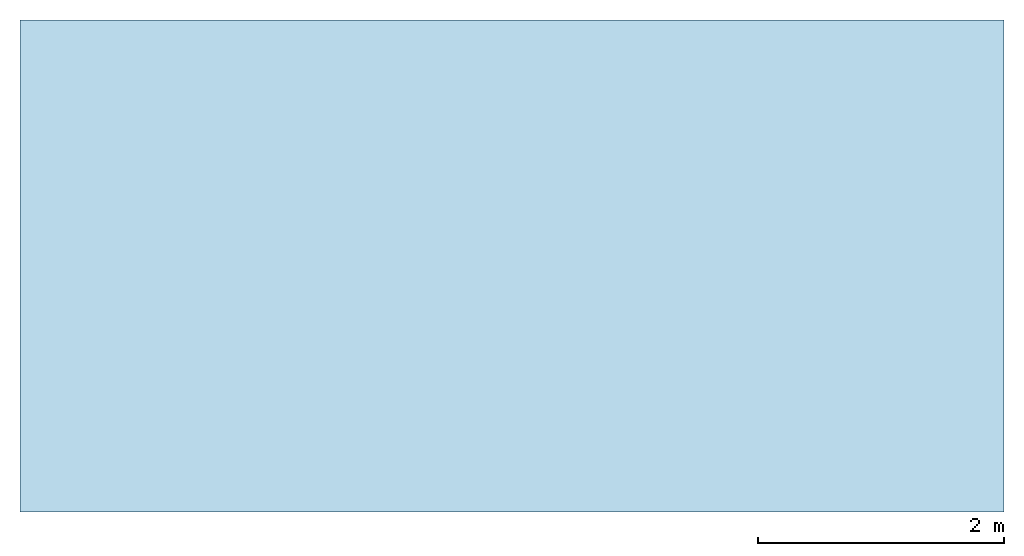
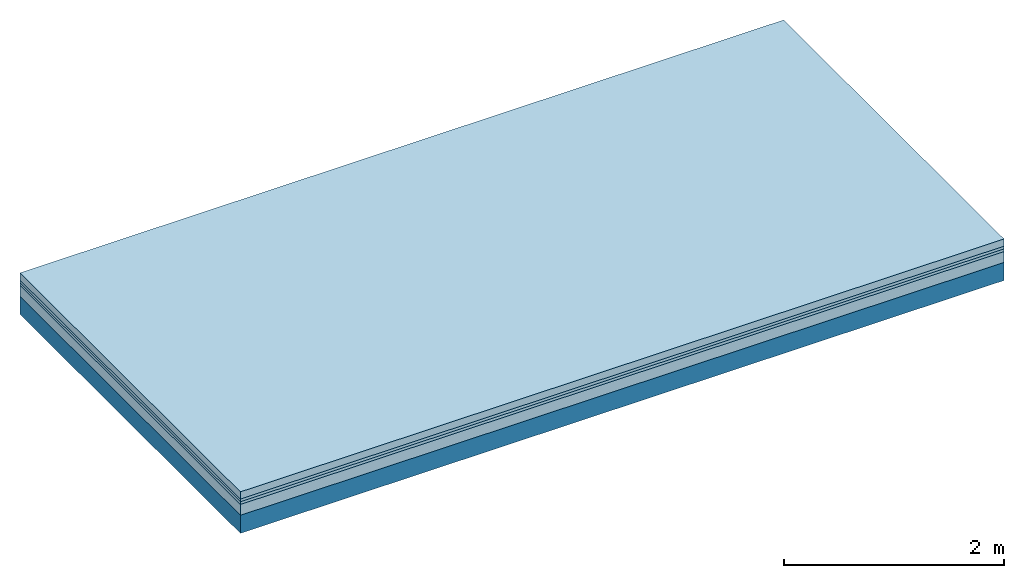
# One storey: 4 plates, 1 member, 1 element without a shape of its own.
"""IFC4 building model written with IfcOpenShell, lengths in metres."""

from ifc_helpers import new_model, si_unit, derived_unit, direction, frame, frame_2d, origin, origin_with_axes, place, context, project, spatial, rectangle, extrude, material, layer, layer_set, type_object, element, aggregate, save


model = new_model("IFC4")

# Units and contexts
plan_context = context("Plan", 3, precision=1e-05, world=origin(), true_north=direction((0.0, 1.0)))
model_context = context("Model", 3, precision=1e-05, world=origin(), true_north=direction((0.0, 1.0)))
ifc_project = project(units=[si_unit("LENGTHUNIT", "METRE"), derived_unit("SOUNDPRESSUREUNIT", [(si_unit("PRESSUREUNIT", "PASCAL", prefix="MICRO"), 0)]), si_unit("ENERGYUNIT", "JOULE", prefix="MEGA"), si_unit("MASSUNIT", "GRAM", prefix="KILO"), derived_unit("THERMALTRANSMITTANCEUNIT", [(si_unit("POWERUNIT", "WATT"), 1), (si_unit("AREAUNIT", "SQUARE_METRE"), -1), (si_unit("THERMODYNAMICTEMPERATUREUNIT", "KELVIN"), -1)]), derived_unit("AREADENSITYUNIT", [(si_unit("MASSUNIT", "GRAM", prefix="KILO"), 1), (si_unit("AREAUNIT", "SQUARE_METRE"), -1)]), derived_unit("USERDEFINED", [(si_unit("ENERGYUNIT", "JOULE", prefix="MEGA"), 1), (si_unit("AREAUNIT", "SQUARE_METRE"), -1)])], contexts=[plan_context, model_context])

# Site, building, storey
site = spatial("IfcSite", under=ifc_project)
building_placement = place(None, origin())
building = spatial("IfcBuilding", under=site, at=building_placement)
storey_placement = place(building_placement, origin())
storey = spatial("IfcBuildingStorey", under=building, at=storey_placement)

# Slab, member, plates
ifc_material_1 = material(Name="Cement screed", Category="04.006")
ifc_layer_1 = layer(ifc_material_1, 0.08, Name="On-material")
ifc_material_2 = material()
ifc_layer_2 = layer(ifc_material_2, 0.03, Name="Impact sound insulation")
ifc_material_3 = material()
ifc_layer_3 = layer(ifc_material_3, 0.03, Name="Additional insulation")
ifc_material_4 = material(Category="03.011")
ifc_layer_4 = layer(ifc_material_4, 0.12, Name="on Supporting structure")
ifc_layer_5 = layer(None, 0.2, Name="Supporting structure")
ifc_layer_set = layer_set([ifc_layer_1, ifc_layer_2, ifc_layer_3, ifc_layer_4, ifc_layer_5])
slab_type = type_object("IfcSlabType", Name="A1097", PredefinedType="NOTDEFINED", material=ifc_layer_set)
slab_placement = place(None, frame((0.0, 0.0, 0.0), z_axis=(0.0, 0.0, -1.0), x_axis=(1.0, 0.0, 0.0)))
slab = element("IfcSlab", 1, at=slab_placement, inside=storey, type_object=slab_type, material=ifc_layer_set, Name="Slab #1")
ifc_material_5 = material()
member_placement = place(slab_placement, origin())
member = element("IfcMember", 2, at=member_placement, material=ifc_material_5, Name="Supporting structure", context=plan_context, shape_type="SweptSolid", body=[
    extrude(rectangle(XDim=1.0, YDim=0.2, at=frame_2d((0.5, 0.1), x_axis=(1.0, 0.0))), frame((0.0, 4.0, 0.26), z_axis=(0.0, -1.0, 0.0), x_axis=(1.0, 0.0, 0.0)), (0.0, 0.0, 1.0), 4.0),
    extrude(rectangle(XDim=1.0, YDim=0.2, at=frame_2d((0.5, 0.1), x_axis=(1.0, 0.0))), frame((1.0, 4.0, 0.26), z_axis=(0.0, -1.0, 0.0), x_axis=(1.0, 0.0, 0.0)), (0.0, 0.0, 1.0), 4.0),
    extrude(rectangle(XDim=1.0, YDim=0.2, at=frame_2d((0.5, 0.1), x_axis=(1.0, 0.0))), frame((2.0, 4.0, 0.26), z_axis=(0.0, -1.0, 0.0), x_axis=(1.0, 0.0, 0.0)), (0.0, 0.0, 1.0), 4.0),
    extrude(rectangle(XDim=1.0, YDim=0.2, at=frame_2d((0.5, 0.1), x_axis=(1.0, 0.0))), frame((3.0, 4.0, 0.26), z_axis=(0.0, -1.0, 0.0), x_axis=(1.0, 0.0, 0.0)), (0.0, 0.0, 1.0), 4.0),
    extrude(rectangle(XDim=1.0, YDim=0.2, at=frame_2d((0.5, 0.1), x_axis=(1.0, 0.0))), frame((4.0, 4.0, 0.26), z_axis=(0.0, -1.0, 0.0), x_axis=(1.0, 0.0, 0.0)), (0.0, 0.0, 1.0), 4.0),
    extrude(rectangle(XDim=1.0, YDim=0.2, at=frame_2d((0.5, 0.1), x_axis=(1.0, 0.0))), frame((5.0, 4.0, 0.26), z_axis=(0.0, -1.0, 0.0), x_axis=(1.0, 0.0, 0.0)), (0.0, 0.0, 1.0), 4.0),
    extrude(rectangle(XDim=1.0, YDim=0.2, at=frame_2d((0.5, 0.1), x_axis=(1.0, 0.0))), frame((6.0, 4.0, 0.26), z_axis=(0.0, -1.0, 0.0), x_axis=(1.0, 0.0, 0.0)), (0.0, 0.0, 1.0), 4.0),
    extrude(rectangle(XDim=1.0, YDim=0.2, at=frame_2d((0.5, 0.1), x_axis=(1.0, 0.0))), frame((7.0, 4.0, 0.26), z_axis=(0.0, -1.0, 0.0), x_axis=(1.0, 0.0, 0.0)), (0.0, 0.0, 1.0), 4.0),
])
plate_1_placement = place(slab_placement, origin())
plate_1 = element("IfcPlate", 3, at=plate_1_placement, material=ifc_material_1, Name="On-material", context=plan_context, shape_type="SweptSolid", body=[
    extrude(rectangle(XDim=8.0, YDim=4.0, at=frame_2d((4.0, 2.0), x_axis=(1.0, 0.0))), origin_with_axes(), (0.0, 0.0, 1.0), 0.08),
])
plate_2_placement = place(slab_placement, origin())
plate_2 = element("IfcPlate", 4, at=plate_2_placement, material=ifc_material_2, Name="Impact sound insulation", context=plan_context, shape_type="SweptSolid", body=[
    extrude(rectangle(XDim=8.0, YDim=4.0, at=frame_2d((4.0, 2.0), x_axis=(1.0, 0.0))), frame((0.0, 0.0, 0.08), z_axis=(0.0, 0.0, 1.0), x_axis=(1.0, 0.0, 0.0)), (0.0, 0.0, 1.0), 0.03),
])
plate_3_placement = place(slab_placement, origin())
plate_3 = element("IfcPlate", 5, at=plate_3_placement, material=ifc_material_3, Name="Additional insulation", context=plan_context, shape_type="SweptSolid", body=[
    extrude(rectangle(XDim=8.0, YDim=4.0, at=frame_2d((4.0, 2.0), x_axis=(1.0, 0.0))), frame((0.0, 0.0, 0.11), z_axis=(0.0, 0.0, 1.0), x_axis=(1.0, 0.0, 0.0)), (0.0, 0.0, 1.0), 0.03),
])
plate_4_placement = place(slab_placement, origin())
plate_4 = element("IfcPlate", 6, at=plate_4_placement, material=ifc_material_4, Name="on Supporting structure", context=plan_context, shape_type="SweptSolid", body=[
    extrude(rectangle(XDim=8.0, YDim=4.0, at=frame_2d((4.0, 2.0), x_axis=(1.0, 0.0))), frame((0.0, 0.0, 0.14), z_axis=(0.0, 0.0, 1.0), x_axis=(1.0, 0.0, 0.0)), (0.0, 0.0, 1.0), 0.12),
])
aggregate(slab, [plate_1, plate_2, plate_3, plate_4, member])

save(model, "model.ifc")
